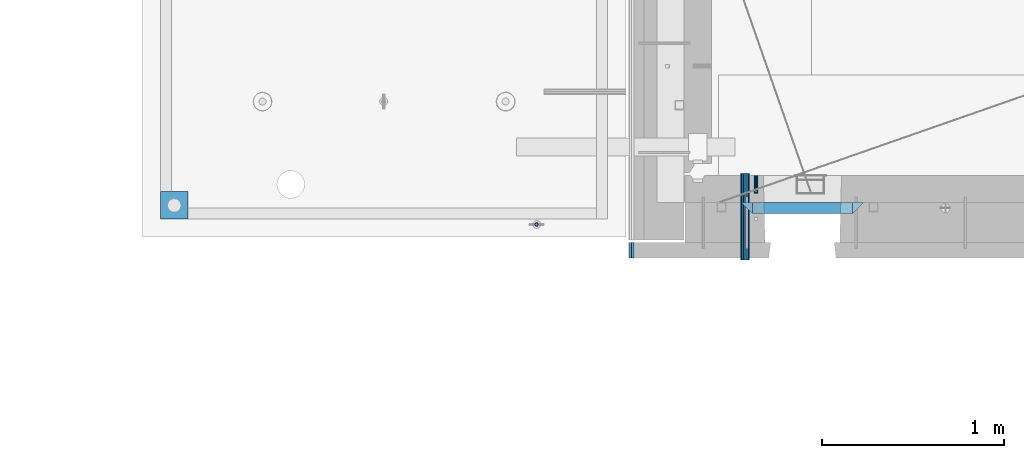
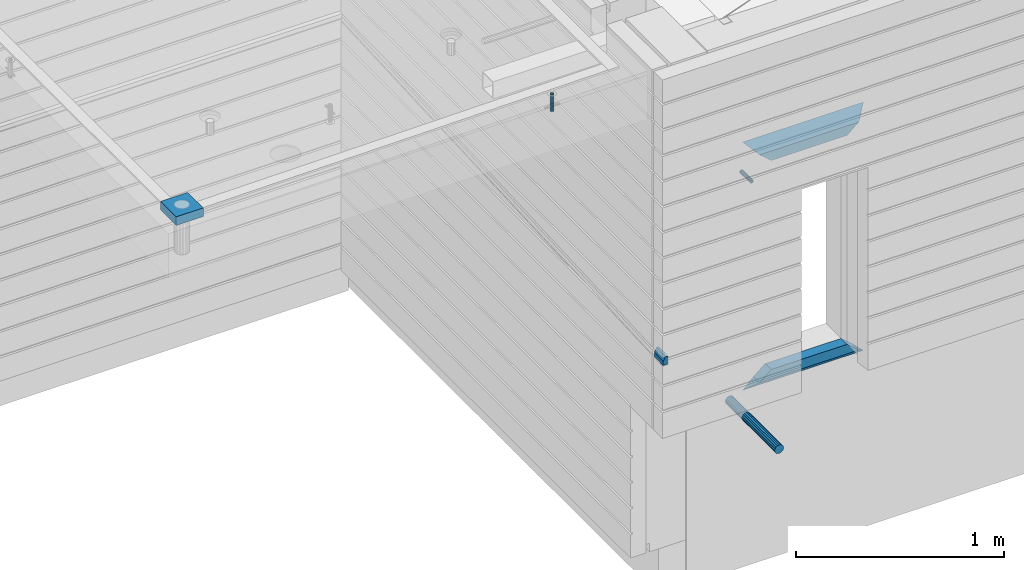
# One storey, part 118 of 325: 9 beams, 5 elements without a shape of their own.
"""IFC2X3 building model written with IfcOpenShell, lengths in millimetres."""

from ifc_helpers import new_model, si_unit, frame, origin_with_axes, place, context, subcontext, project, spatial, faceted_brep, material, type_object, element, aggregate, save


model = new_model("IFC2X3")

# Units and contexts
model_context = context("Model", 3, precision=1e-05, world=origin_with_axes())
body_context = subcontext(model_context, "Body", "Model", "MODEL_VIEW")
ifc_project = project(units=[si_unit("LENGTHUNIT", "METRE", prefix="MILLI"), si_unit("AREAUNIT", "SQUARE_METRE"), si_unit("VOLUMEUNIT", "CUBIC_METRE"), si_unit("MASSUNIT", "GRAM", prefix="KILO"), si_unit("TIMEUNIT", "SECOND"), si_unit("PLANEANGLEUNIT", "RADIAN"), si_unit("SOLIDANGLEUNIT", "STERADIAN"), si_unit("THERMODYNAMICTEMPERATUREUNIT", "DEGREE_CELSIUS"), si_unit("LUMINOUSINTENSITYUNIT", "LUMEN")], contexts=[model_context])

# Site, building, storey
site_placement = place(None, origin_with_axes())
site = spatial("IfcSite", under=ifc_project, at=site_placement, CompositionType="ELEMENT")
building_placement = place(site_placement, origin_with_axes())
building = spatial("IfcBuilding", under=site, at=building_placement, CompositionType="ELEMENT")
storey_placement = place(building_placement, origin_with_axes())
storey = spatial("IfcBuildingStorey", under=building, at=storey_placement, Name="1", CompositionType="ELEMENT", Elevation=0.0)

# Assembly, beam
assembly_1_placement = place(storey_placement, origin_with_axes())
assembly_1 = element("IfcElementAssembly", 1, at=assembly_1_placement, inside=storey, AssemblyPlace="NOTDEFINED", PredefinedType="REINFORCEMENT_UNIT")
ifc_material_1 = material(Name="CONCRETE/Concrete_Undefined")
beam_type_1 = type_object("IfcBeamType", PredefinedType="NOTDEFINED")
beam_1_placement = place(assembly_1_placement, frame((7135.00199083741, 7835.00021949177, 84683.0), z_axis=(0.0, 0.0, 1.0), x_axis=(0.999999999595185, 2.84539999907424e-05, 0.0)))
beam_1 = element("IfcBeam", 2, at=beam_1_placement, type_object=beam_type_1, material=ifc_material_1, context=body_context, shape_type="Brep", body=[
    faceted_brep([(0.0, 75.0, -25.0), (1.81898940354586e-12, 75.0, 25.0), (150.000890444859, 75.0000000000009, 25.0), (150.000890444859, 75.0000000000009, -25.0), (1.81898940354586e-12, -75.0000000000009, 25.0), (150.00089044486, -74.9999999999991, 25.0), (0.0, -75.0, -25.0), (150.00089044486, -74.9999999999991, -25.0)], [[[0, 1, 2, 3]], [[1, 4, 5, 2]], [[4, 6, 7, 5]], [[6, 0, 3, 7]], [[5, 7, 3, 2]], [[6, 4, 1, 0]]]),
])

# Assemblies, beam
assembly_2_placement = place(storey_placement, origin_with_axes())
assembly_2 = element("IfcElementAssembly", 3, at=assembly_2_placement, inside=storey, AssemblyPlace="NOTDEFINED", PredefinedType="REINFORCEMENT_UNIT")
assembly_3_placement = place(assembly_2_placement, origin_with_axes())
assembly_3 = element("IfcElementAssembly", 4, at=assembly_3_placement, Name="Steel Assembly", AssemblyPlace="NOTDEFINED", PredefinedType="RIGID_FRAME")
ifc_material_2 = material(Name="STEEL/Steel_Undefined")
beam_type_2 = type_object("IfcBeamType", PredefinedType="NOTDEFINED")
beam_2_placement = place(assembly_3_placement, frame((10405.0053216359, 8000.0, 83685.0), z_axis=(1.0, 0.0, 0.0), x_axis=(0.0, -1.0, 0.0)))
beam_2 = element("IfcBeam", 5, at=beam_2_placement, type_object=beam_type_2, material=ifc_material_2, Name="M16", context=body_context, shape_type="Brep", body=[
    faceted_brep([(0.0, -8.49999999999272, -1.45519152283669e-11), (0.0, -7.36121593215648, 4.24999999998545), (100.000000000262, -7.36121593215648, 4.24999999998545), (100.000000000262, -8.49999999999272, -1.45519152283669e-11), (0.0, -4.24999999998545, 7.36121593216376), (100.000000000262, -4.24999999998545, 7.36121593216376), (0.0, 1.45519152283669e-11, 8.49999999998545), (100.000000000262, 1.45519152283669e-11, 8.49999999998545), (0.0, 4.25000000001455, 7.36121593216376), (100.000000000262, 4.25000000001455, 7.36121593216376), (0.0, 7.36121593217104, 4.24999999998545), (100.000000000262, 7.36121593217104, 4.24999999998545), (0.0, 8.50000000000728, 0.0), (100.000000000262, 8.50000000000728, 0.0), (0.0, 7.36121593217104, -4.25000000001455), (100.000000000262, 7.36121593217104, -4.25000000001455), (0.0, 4.25000000000728, -7.36121593219286), (100.000000000262, 4.25000000000728, -7.36121593219286), (0.0, 7.27595761418343e-12, -8.5), (100.000000000262, 7.27595761418343e-12, -8.5), (0.0, -4.24999999999272, -7.36121593217831), (100.000000000262, -4.24999999999272, -7.36121593217831), (0.0, -7.36121593215648, -4.25), (100.000000000262, -7.36121593215648, -4.25), (0.0, -10.4999999999927, -1.45519152283669e-11), (0.0, -9.09326673972828, -5.25000000001455), (100.000000000262, -9.09326673972828, -5.25000000001455), (100.000000000262, -10.4999999999927, -1.45519152283669e-11), (0.0, -5.24999999998545, -9.09326673974283), (100.000000000262, -5.24999999998545, -9.09326673974283), (0.0, 7.27595761418343e-12, -10.5), (100.000000000262, 7.27595761418343e-12, -10.5), (0.0, 5.25000000001455, -9.09326673975738), (100.000000000262, 5.25000000001455, -9.09326673975738), (0.0, 9.09326673975011, -5.25000000001455), (100.000000000262, 9.09326673975011, -5.25000000001455), (0.0, 10.5000000000073, -1.45519152283669e-11), (100.000000000262, 10.5000000000073, -1.45519152283669e-11), (0.0, 9.09326673975011, 5.25), (100.000000000262, 9.09326673975011, 5.25), (0.0, 5.25000000000728, 9.09326673972828), (100.000000000262, 5.25000000000728, 9.09326673972828), (0.0, 1.45519152283669e-11, 10.4999999999854), (100.000000000262, 1.45519152283669e-11, 10.4999999999854), (0.0, -5.24999999999272, 9.09326673972828), (100.000000000262, -5.24999999999272, 9.09326673972828), (0.0, -9.09326673972828, 5.24999999998545), (100.000000000262, -9.09326673972828, 5.24999999998545)], [[[0, 1, 2, 3]], [[1, 4, 5, 2]], [[4, 6, 7, 5]], [[6, 8, 9, 7]], [[8, 10, 11, 9]], [[10, 12, 13, 11]], [[12, 14, 15, 13]], [[14, 16, 17, 15]], [[16, 18, 19, 17]], [[18, 20, 21, 19]], [[20, 22, 23, 21]], [[22, 0, 3, 23]], [[24, 25, 26, 27]], [[25, 28, 29, 26]], [[28, 30, 31, 29]], [[30, 32, 33, 31]], [[32, 34, 35, 33]], [[34, 36, 37, 35]], [[36, 38, 39, 37]], [[38, 40, 41, 39]], [[40, 42, 43, 41]], [[42, 44, 45, 43]], [[44, 46, 47, 45]], [[46, 24, 27, 47]], [[29, 31, 33, 35, 37, 39, 41, 43, 45, 47, 27, 26], [5, 7, 9, 11, 13, 15, 17, 19, 21, 23, 3, 2]], [[46, 44, 42, 40, 38, 36, 34, 32, 30, 28, 25, 24], [22, 20, 18, 16, 14, 12, 10, 8, 6, 4, 1, 0]]]),
])
aggregate(assembly_3, [beam_2])

# Assembly
assembly_4_placement = place(assembly_1_placement, origin_with_axes())
assembly_4 = element("IfcElementAssembly", 6, at=assembly_4_placement, Name="Steel Assembly", AssemblyPlace="NOTDEFINED", PredefinedType="RIGID_FRAME")

aggregate(assembly_1, [assembly_4, beam_1])

# Beam
ifc_material_3 = material(Name="STEEL/1.4301")
beam_type_3 = type_object("IfcBeamType", PredefinedType="NOTDEFINED")
beam_3_placement = place(assembly_4_placement, frame((9200.00647225436, 7729.99938297495, 84725.999999991), z_axis=(-3.40399999911671e-06, 0.999999999994206, 0.0), x_axis=(0.0, 0.0, -1.0)))
beam_3 = element("IfcBeam", 7, at=beam_3_placement, type_object=beam_type_3, material=ifc_material_3, context=body_context, shape_type="Brep", body=[
    faceted_brep([(0.0, -8.0, 0.0), (0.0, -6.92820323027263, 4.0), (100.000000000029, -6.92820323027263, 4.0), (100.000000000029, -7.99999999999636, 0.0), (0.0, -4.0, 6.92820323027627), (100.000000000029, -4.0, 6.92820323027536), (0.0, 0.0, 8.0), (100.000000000029, 3.63797880709171e-12, 8.0), (0.0, 4.0, 6.92820323027627), (100.000000000029, 4.0, 6.92820323027536), (0.0, 6.92820323027263, 4.0), (100.000000000029, 6.92820323027627, 3.99999999999909), (0.0, 8.0, 0.0), (100.000000000029, 8.0, 0.0), (0.0, 6.92820323027263, -4.0), (100.000000000029, 6.92820323027627, -4.00000000000091), (0.0, 4.0, -6.92820323027627), (100.000000000029, 4.00000000000364, -6.92820323027536), (0.0, 0.0, -8.0), (100.000000000029, 3.63797880709171e-12, -8.00000000000091), (0.0, -4.0, -6.92820323027627), (100.000000000029, -3.99999999999636, -6.92820323027627), (0.0, -6.92820323027263, -4.0), (100.000000000029, -6.92820323027263, -4.0), (0.0, -10.4999999999927, -1.45519152283669e-11), (0.0, -9.09326673972828, -5.25000000001455), (100.000000000262, -9.09326673972828, -5.25000000001455), (100.000000000262, -10.4999999999927, -1.45519152283669e-11), (0.0, -5.24999999998545, -9.09326673974283), (100.000000000262, -5.24999999998545, -9.09326673974283), (0.0, 7.27595761418343e-12, -10.5), (100.000000000262, 7.27595761418343e-12, -10.5), (0.0, 5.25000000001455, -9.09326673975738), (100.000000000262, 5.25000000001455, -9.09326673975738), (0.0, 9.09326673975011, -5.25000000001455), (100.000000000262, 9.09326673975011, -5.25000000001455), (0.0, 10.5000000000073, -1.45519152283669e-11), (100.000000000262, 10.5000000000073, -1.45519152283669e-11), (0.0, 9.09326673975011, 5.25), (100.000000000262, 9.09326673975011, 5.25), (0.0, 5.25000000000728, 9.09326673972828), (100.000000000262, 5.25000000000728, 9.09326673972828), (0.0, 1.45519152283669e-11, 10.4999999999854), (100.000000000262, 1.45519152283669e-11, 10.4999999999854), (0.0, -5.24999999999272, 9.09326673972828), (100.000000000262, -5.24999999999272, 9.09326673972828), (0.0, -9.09326673972828, 5.24999999998545), (100.000000000262, -9.09326673972828, 5.24999999998545)], [[[0, 1, 2, 3]], [[1, 4, 5, 2]], [[4, 6, 7, 5]], [[6, 8, 9, 7]], [[8, 10, 11, 9]], [[10, 12, 13, 11]], [[12, 14, 15, 13]], [[14, 16, 17, 15]], [[16, 18, 19, 17]], [[18, 20, 21, 19]], [[20, 22, 23, 21]], [[22, 0, 3, 23]], [[24, 25, 26, 27]], [[25, 28, 29, 26]], [[28, 30, 31, 29]], [[30, 32, 33, 31]], [[32, 34, 35, 33]], [[34, 36, 37, 35]], [[36, 38, 39, 37]], [[38, 40, 41, 39]], [[40, 42, 43, 41]], [[42, 44, 45, 43]], [[44, 46, 47, 45]], [[46, 24, 27, 47]], [[29, 31, 33, 35, 37, 39, 41, 43, 45, 47, 27, 26], [5, 7, 9, 11, 13, 15, 17, 19, 21, 23, 3, 2]], [[46, 44, 42, 40, 38, 36, 34, 32, 30, 28, 25, 24], [22, 20, 18, 16, 14, 12, 10, 8, 6, 4, 1, 0]]]),
])

aggregate(assembly_4, [beam_3])

ifc_material_4 = material(Name="TIMBER/T24")
beam_type_4 = type_object("IfcBeamType", PredefinedType="NOTDEFINED")
beam_4_placement = place(assembly_2_placement, frame((9722.47, 7631.21988125754, 83092.5481157334), z_axis=(1.0, 0.0, 0.0), x_axis=(0.0, -0.998808802312005, -0.0487952500153176)))
beam_4 = element("IfcBeam", 8, at=beam_4_placement, type_object=beam_type_4, material=ifc_material_4, context=body_context, shape_type="Brep", body=[
    faceted_brep([(0.0, -25.0, 0.0), (-1.45519152283669e-11, -3.63797880709171e-12, -12.5), (85.1012461205373, -1.91066646948457e-08, -12.5), (85.1012461205355, -25.0000000000146, -6.82375684846193e-08), (0.0, 25.0, -12.5), (0.0, 25.0, 12.5), (85.1012461205373, 25.0, 12.5), (85.1012461205373, 25.0, -12.5), (0.0, -25.0, 12.5), (85.1012461205355, -25.0000000000146, 12.5)], [[[0, 1, 2, 3]], [[4, 5, 6, 7]], [[5, 8, 9, 6]], [[9, 8, 0, 3]], [[7, 6, 9, 3, 2]], [[4, 7, 2, 1]], [[8, 5, 4, 1, 0]]]),
])

ifc_material_5 = material(Name="CONCRETE/C25/30")
beam_type_5 = type_object("IfcBeamType", PredefinedType="NOTDEFINED")
beam_5_placement = place(assembly_2_placement, frame((10384.9999512688, 7820.0, 83885.0), z_axis=(0.0, 0.0, -1.0), x_axis=(1.0, 0.0, 0.0)))
beam_5 = element("IfcBeam", 9, at=beam_5_placement, type_object=beam_type_5, material=ifc_material_5, context=body_context, shape_type="Brep", body=[
    faceted_brep([(485.946518150537, -30.0, 24.0540540540533), (484.324896528915, 30.0, 25.6756756756804), (65.6762478802648, 30.0, 25.6756756756804), (64.0546262586431, -30.0, 24.0540540540533), (65.6762478802648, 30.0, 26.2939267421607), (64.0546262586431, -30.0, 24.9039653525251), (0.0, 30.0, -30.0), (0.0, -30.0, -30.0), (550.00057220459, -30.0, -30.0), (485.946518150537, -30.0, 24.9034748914419), (484.324896528915, 30.0, 26.293436281092), (550.00057220459, 30.0, -30.0)], [[[0, 1, 2, 3]], [[3, 2, 4, 5]], [[5, 4, 6, 7]], [[0, 3, 5, 7, 8, 9]], [[1, 0, 9, 10]], [[6, 4, 2, 1, 10, 11]], [[7, 6, 11, 8]], [[8, 11, 10, 9]]]),
])

beam_6_placement = place(assembly_2_placement, frame((10324.9999512688, 7820.0, 83945.0), z_axis=(0.0, 0.0, -1.0), x_axis=(1.0, 0.0, 0.0)))
beam_6 = element("IfcBeam", 10, at=beam_6_placement, type_object=beam_type_5, material=ifc_material_5, context=body_context, shape_type="Brep", body=[
    faceted_brep([(60.0000000000073, 30.0, 30.0), (0.0, -30.0, -30.0), (60.0000000000073, -30.0, 30.0), (670.00057220459, -30.0, -30.0), (610.00057220459, -30.0, 30.0), (610.00057220459, 30.0, 30.0)], [[[0, 1, 2]], [[2, 1, 3, 4]], [[0, 2, 4, 5]], [[1, 0, 5, 3]], [[3, 5, 4]]]),
])

beam_7_placement = place(assembly_2_placement, frame((10935.0005234733, 7820.0, 82610.0), z_axis=(0.0, 0.0, 1.0), x_axis=(-1.0, 3.00000001838171e-08, 0.0)))
beam_7 = element("IfcBeam", 11, at=beam_7_placement, type_object=beam_type_5, material=ifc_material_5, context=body_context, shape_type="Brep", body=[
    faceted_brep([(485.945945945947, -30.0, 24.0540540540533), (484.324324324325, 30.0, 25.6756756756804), (65.6756756756768, 30.0, 25.6756756756804), (64.0540540540533, -30.0, 24.0540540540533), (485.945945945947, -30.0, 24.9039653525106), (484.324324324325, 30.0, 26.2939267421607), (550.00057220459, -30.0, -30.0), (550.00057220459, 30.0, -30.0), (0.0, -30.0, -30.0), (0.0, 30.0, -30.0), (65.6756756756768, 30.0, 26.293436281092), (64.0540540540533, -30.0, 24.9034748914419)], [[[0, 1, 2, 3]], [[1, 0, 4, 5]], [[4, 6, 7, 5]], [[8, 9, 7, 6]], [[2, 1, 5, 7, 9, 10]], [[3, 2, 10, 11]], [[6, 4, 0, 3, 11, 8]], [[8, 11, 10, 9]]]),
])

beam_8_placement = place(assembly_2_placement, frame((10995.0005234733, 7820.0, 82550.0), z_axis=(0.0, 0.0, 1.0), x_axis=(-1.0, 3.00000001838171e-08, 0.0)))
beam_8 = element("IfcBeam", 12, at=beam_8_placement, type_object=beam_type_5, material=ifc_material_5, context=body_context, shape_type="Brep", body=[
    faceted_brep([(60.0000000000073, -30.0, 30.0), (0.0, -30.0, -30.0), (670.00057220459, -30.0, -30.0), (610.00057220459, -30.0, 30.0), (610.00057220459, 30.0, 30.0), (60.0000000000073, 30.0, 30.0)], [[[0, 1, 2, 3]], [[2, 4, 3]], [[5, 0, 3, 4]], [[5, 1, 0]], [[1, 5, 4, 2]]]),
])

aggregate(assembly_2, [beam_4, assembly_3, beam_5, beam_6, beam_7, beam_8])

# Assembly, beam
assembly_5_placement = place(storey_placement, origin_with_axes())
assembly_5 = element("IfcElementAssembly", 13, at=assembly_5_placement, inside=storey, Name="Steel Assembly", AssemblyPlace="NOTDEFINED", PredefinedType="NOTDEFINED")
ifc_material_6 = material()
beam_type_6 = type_object("IfcBeamType", Name="D50", PredefinedType="NOTDEFINED")
beam_9_placement = place(assembly_5_placement, frame((10345.6817626953, 8009.79254599883, 82360.0), z_axis=(0.0, 0.0, 1.0), x_axis=(0.0, -1.0, 0.0)))
beam_9 = element("IfcBeam", 14, at=beam_9_placement, type_object=beam_type_6, material=ifc_material_6, ObjectType="D50", context=body_context, shape_type="Brep", body=[
    faceted_brep([(0.0, -25.0, 0.0), (-3.63797880709171e-12, -23.0969883127837, -9.56708580912891), (475.001831054677, -23.0969883127818, -9.56708580913255), (475.001831054677, -25.0, 0.0), (-3.63797880709171e-12, -17.6776695296576, -17.6776695296649), (475.001831054677, -17.677669529663, -17.6776695296576), (-1.09139364212751e-11, -9.56708580913255, -23.0969883127837), (475.001831054677, -9.56708580912709, -23.0969883127837), (-1.09139364212751e-11, 0.0, -25.0), (475.001831054677, 0.0, -25.0), (-1.09139364212751e-11, 9.56708580913255, -23.0969883127837), (475.001831054677, 9.56708580912709, -23.0969883127837), (-3.63797880709171e-12, 17.6776695296576, -17.6776695296649), (475.001831054677, 17.677669529663, -17.6776695296576), (-3.63797880709171e-12, 23.0969883127837, -9.56708580912891), (475.001831054677, 23.0969883127818, -9.56708580913255), (0.0, 25.0, 0.0), (475.001831054677, 25.0, 0.0), (7.27595761418343e-12, 23.0969883127837, 9.56708580912891), (475.001831054677, 23.0969883127818, 9.56708580913255), (7.27595761418343e-12, 17.6776695296576, 17.6776695296649), (475.001831054677, 17.677669529663, 17.6776695296576), (1.45519152283669e-11, 9.56708580913255, 23.0969883127837), (475.001831054677, 9.56708580912709, 23.0969883127837), (1.09139364212751e-11, 0.0, 25.0), (475.001831054677, 0.0, 25.0), (1.45519152283669e-11, -9.56708580913255, 23.0969883127837), (475.001831054677, -9.56708580912709, 23.0969883127837), (7.27595761418343e-12, -17.6776695296576, 17.6776695296649), (475.001831054677, -17.677669529663, 17.6776695296576), (7.27595761418343e-12, -23.0969883127837, 9.56708580912891), (475.001831054677, -23.0969883127818, 9.56708580913255)], [[[0, 1, 2, 3]], [[1, 4, 5, 2]], [[4, 6, 7, 5]], [[6, 8, 9, 7]], [[8, 10, 11, 9]], [[10, 12, 13, 11]], [[12, 14, 15, 13]], [[14, 16, 17, 15]], [[16, 18, 19, 17]], [[18, 20, 21, 19]], [[20, 22, 23, 21]], [[22, 24, 25, 23]], [[24, 26, 27, 25]], [[26, 28, 29, 27]], [[28, 30, 31, 29]], [[30, 0, 3, 31]], [[5, 7, 9, 11, 13, 15, 17, 19, 21, 23, 25, 27, 29, 31, 3, 2]], [[30, 28, 26, 24, 22, 20, 18, 16, 14, 12, 10, 8, 6, 4, 1, 0]]]),
])
aggregate(assembly_5, [beam_9])

save(model, "model.ifc")
